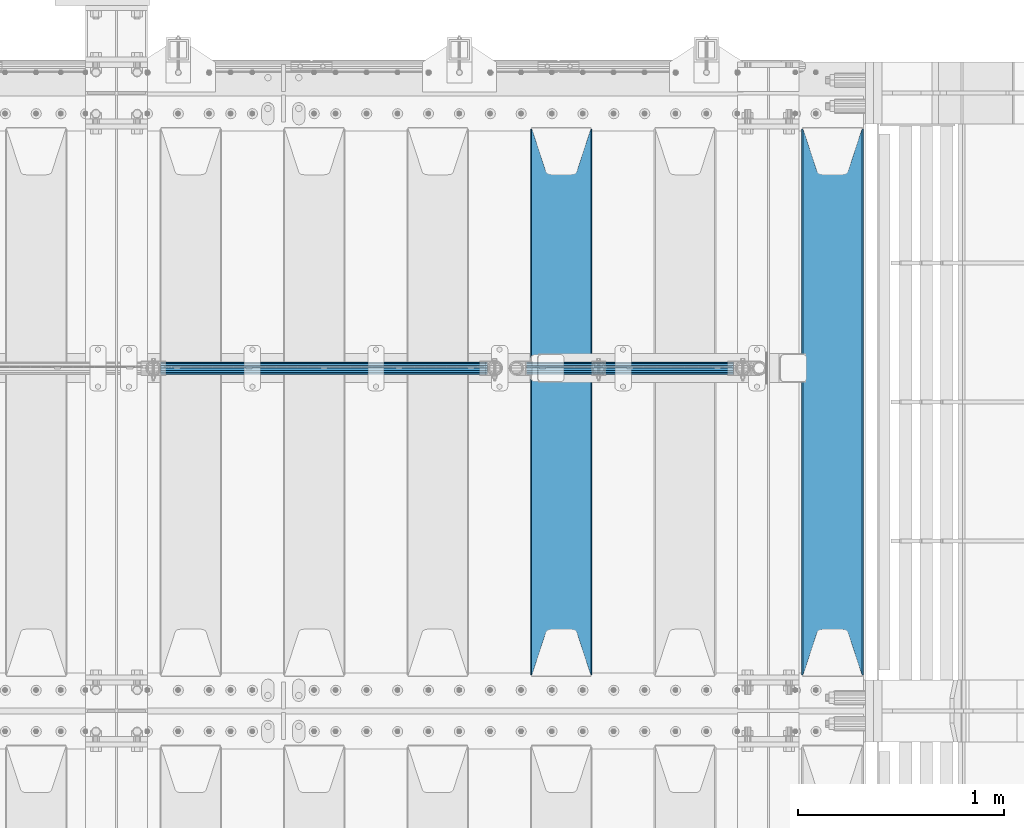
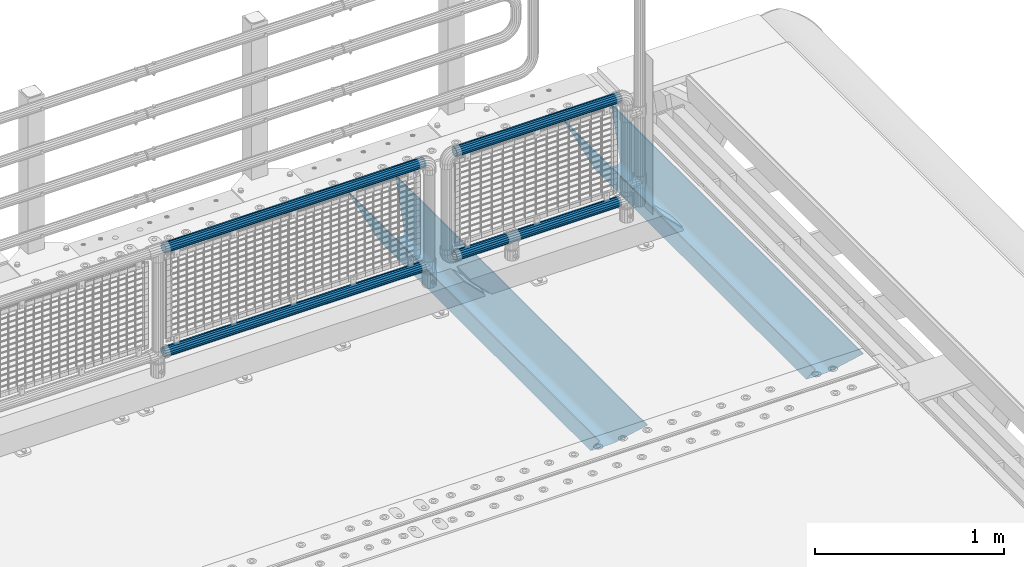
# One storey, part 101 of 193: 6 beams.
"""IFC2X3 building model written with IfcOpenShell, lengths in millimetres."""

from ifc_helpers import new_model, si_unit, frame, origin_with_axes, place, context, subcontext, project, spatial, faceted_brep, material, type_object, element, save


model = new_model("IFC2X3")

# Units and contexts
model_context = context("Model", 3, precision=1e-05, world=origin_with_axes())
body_context = subcontext(model_context, "Body", "Model", "MODEL_VIEW")
ifc_project = project(units=[si_unit("LENGTHUNIT", "METRE", prefix="MILLI"), si_unit("AREAUNIT", "SQUARE_METRE"), si_unit("VOLUMEUNIT", "CUBIC_METRE"), si_unit("MASSUNIT", "GRAM", prefix="KILO"), si_unit("TIMEUNIT", "SECOND"), si_unit("PLANEANGLEUNIT", "RADIAN"), si_unit("SOLIDANGLEUNIT", "STERADIAN"), si_unit("THERMODYNAMICTEMPERATUREUNIT", "DEGREE_CELSIUS"), si_unit("LUMINOUSINTENSITYUNIT", "LUMEN")], contexts=[model_context])

# Site, building, storey
site_placement = place(None, origin_with_axes())
site = spatial("IfcSite", under=ifc_project, at=site_placement, CompositionType="ELEMENT")
building_placement = place(site_placement, origin_with_axes())
building = spatial("IfcBuilding", under=site, at=building_placement, Name="Standard", CompositionType="ELEMENT")
storey_placement = place(building_placement, origin_with_axes())
storey = spatial("IfcBuildingStorey", under=building, at=storey_placement, Name="Undefined", CompositionType="ELEMENT", Elevation=0.0)

# Beams
ifc_material_1 = material(Name="STEEL/S355N")
beam_type_1 = type_object("IfcBeamType", PredefinedType="NOTDEFINED")
beam_1_placement = place(storey_placement, frame((-28583.0, 27175.0, -115.0), z_axis=(0.0, 0.0, 1.0), x_axis=(0.0, 1.0, 0.0)))
element("IfcBeam", 1, at=beam_1_placement, inside=storey, type_object=beam_type_1, material=ifc_material_1, context=body_context, shape_type="Brep", body=[
    faceted_brep([(0.0, 150.0, 115.0), (0.0, 143.689999999999, 115.0), (2650.00000000297, 143.689999999999, 115.0), (2650.00000000297, 150.0, 115.0), (2650.00000000297, 142.059565218398, 110.000000003094), (2650.00000000297, 148.3695652184, 110.000000003094), (2441.90079219209, -80.1103600731112, -98.0992078077845), (2437.7588105432, -77.5672621345584, -102.241189456673), (2434.06523489747, -74.4080125315522, -105.934765102404), (2430.9108609509, -70.710272125576, -109.089139048974), (2428.37322971128, -66.5649389910068, -111.626770288588), (2426.51472138055, -62.0739139532889, -113.485278619323), (2425.38102192092, -57.3475956567672, -114.618978078955), (2424.99999999988, -52.5021667386536, -115.0), (2424.99999999988, 52.5021667386536, -115.0), (2425.38102192092, 57.3475956567672, -114.618978078955), (2426.51472138055, 62.0739139532889, -113.485278619323), (2428.37322971128, 66.5649389910068, -111.626770288588), (2430.9108609509, 70.710272125576, -109.089139048974), (2434.06523489747, 74.4080125315522, -105.934765102404), (2437.7588105432, 77.5672621345584, -102.241189456673), (2441.90079219209, 80.1103600731112, -98.0992078077846), (2446.38936140512, 81.9747917625791, -93.6106385947584), (2448.2494850041, 76.2713538057251, -91.7505149957729), (2444.62967112263, 74.76777986261, -95.3703288772456), (2441.28936334127, 72.7168944282894, -98.710636658607), (2438.31067330439, 70.1691124903846, -101.689326695487), (2435.76682334748, 67.1870637758839, -104.233176652398), (2433.72034654134, 63.8440531834895, -106.279653458539), (2432.22154950042, 60.222258798236, -107.778450499454), (2431.30727574265, 56.4107117849089, -108.692724257221), (2430.99999999987, 52.5031078186876, -109.0), (2430.99999999987, -52.5031078186876, -109.0), (2431.30727574265, -56.4107117849089, -108.692724257221), (2432.22154950042, -60.222258798236, -107.778450499454), (2433.72034654134, -63.8440531834895, -106.279653458539), (2435.76682334748, -67.1870637758839, -104.233176652398), (2438.31067330439, -70.1691124903846, -101.689326695487), (2441.28936334127, -72.7168944282894, -98.7106366586071), (2444.62967112263, -74.76777986261, -95.3703288772457), (2448.2494850041, -76.2713538057251, -91.7505149957729), (2650.00000000297, -142.059565218398, 110.000000003094), (2650.00000000297, -148.3695652184, 110.000000003094), (2446.38936140512, -81.9747917625791, -93.6106385947584), (2650.00000000297, -143.689999999999, 115.0), (2650.00000000297, -150.0, 115.0), (0.0, -143.689999999999, 115.0), (0.0, -150.0, 115.0), (0.0, -148.369565218261, 110.000000002667), (203.610638597427, -81.9747917625791, -93.6106385947584), (208.099207810446, -80.1103600731112, -98.0992078077845), (212.241189459342, -77.5672621345584, -102.241189456673), (215.93476510507, -74.4080125315522, -105.934765102404), (219.089139051641, -70.710272125576, -109.089139048974), (221.626770291256, -66.5649389910068, -111.626770288588), (223.485278621989, -62.0739139532889, -113.485278619323), (224.618978081624, -57.3475956567672, -114.618978078955), (225.000000002663, -52.5021667386536, -115.0), (225.000000002663, 52.5021667386536, -115.0), (224.618978081624, 57.3475956567672, -114.618978078955), (223.485278621989, 62.0739139532889, -113.485278619323), (221.626770291256, 66.5649389910068, -111.626770288588), (219.089139051641, 70.710272125576, -109.089139048974), (215.93476510507, 74.4080125315522, -105.934765102404), (212.241189459342, 77.5672621345584, -102.241189456673), (208.099207810446, 80.1103600731112, -98.0992078077846), (203.610638597427, 81.9747917625791, -93.6106385947584), (0.0, 148.369565218261, 110.000000002667), (0.0, 142.05956521826, 110.000000002667), (201.750514998439, 76.2713538057251, -91.7505149957729), (205.370328879915, 74.76777986261, -95.3703288772456), (208.710636661275, 72.7168944282894, -98.710636658607), (211.689326698157, 70.1691124903846, -101.689326695487), (214.233176655063, 67.1870637758839, -104.233176652398), (216.279653461206, 63.8440531834895, -106.279653458539), (217.778450502123, 60.222258798236, -107.778450499454), (218.69272425989, 56.4107117849089, -108.692724257221), (219.00000000267, 52.5031078186876, -109.0), (219.00000000267, -52.5031078186876, -109.0), (218.69272425989, -56.4107117849089, -108.692724257221), (217.778450502123, -60.222258798236, -107.778450499454), (216.279653461206, -63.8440531834895, -106.279653458539), (214.233176655063, -67.1870637758839, -104.233176652398), (211.689326698157, -70.1691124903846, -101.689326695487), (208.710636661275, -72.7168944282894, -98.7106366586071), (205.370328879915, -74.76777986261, -95.3703288772457), (201.750514998439, -76.2713538057251, -91.7505149957729), (0.0, -142.05956521826, 110.000000002667)], [[[0, 1, 2, 3]], [[3, 2, 4, 5]], [[6, 7, 8, 9, 10, 11, 12, 13, 14, 15, 16, 17, 18, 19, 20, 21, 22, 5, 4, 23, 24, 25, 26, 27, 28, 29, 30, 31, 32, 33, 34, 35, 36, 37, 38, 39, 40, 41, 42, 43]], [[44, 45, 42, 41]], [[46, 47, 45, 44]], [[43, 42, 45, 47, 48, 49]], [[6, 43, 49, 50]], [[7, 6, 50, 51]], [[8, 7, 51, 52]], [[9, 8, 52, 53]], [[10, 9, 53, 54]], [[11, 10, 54, 55]], [[12, 11, 55, 56]], [[13, 12, 56, 57]], [[14, 13, 57, 58]], [[15, 14, 58, 59]], [[16, 15, 59, 60]], [[17, 16, 60, 61]], [[18, 17, 61, 62]], [[19, 18, 62, 63]], [[20, 19, 63, 64]], [[21, 20, 64, 65]], [[22, 21, 65, 66]], [[0, 3, 5, 22, 66, 67]], [[1, 0, 67, 68]], [[23, 4, 2, 1, 68, 69]], [[24, 23, 69, 70]], [[25, 24, 70, 71]], [[26, 25, 71, 72]], [[27, 26, 72, 73]], [[28, 27, 73, 74]], [[29, 28, 74, 75]], [[30, 29, 75, 76]], [[31, 30, 76, 77]], [[32, 31, 77, 78]], [[33, 32, 78, 79]], [[34, 33, 79, 80]], [[35, 34, 80, 81]], [[36, 35, 81, 82]], [[37, 36, 82, 83]], [[38, 37, 83, 84]], [[39, 38, 84, 85]], [[40, 39, 85, 86]], [[46, 44, 41, 40, 86, 87]], [[47, 46, 87, 48]], [[86, 85, 84, 83, 82, 81, 80, 79, 78, 77, 76, 75, 74, 73, 72, 71, 70, 69, 68, 67, 66, 65, 64, 63, 62, 61, 60, 59, 58, 57, 56, 55, 54, 53, 52, 51, 50, 49, 48, 87]]]),
])
beam_2_placement = place(storey_placement, frame((-29900.0, 27175.0, -115.0), z_axis=(0.0, 0.0, 1.0), x_axis=(0.0, 1.0, 0.0)))
element("IfcBeam", 2, at=beam_2_placement, inside=storey, type_object=beam_type_1, material=ifc_material_1, context=body_context, shape_type="Brep", body=[
    faceted_brep([(0.0, 150.0, 115.0), (0.0, 143.689999999999, 115.0), (2650.00000000297, 143.689999999999, 115.0), (2650.00000000297, 150.0, 115.0), (2650.00000000297, 142.059565218398, 110.000000003094), (2650.00000000297, 148.3695652184, 110.000000003094), (2441.90079219209, -80.1103600731112, -98.0992078077845), (2437.7588105432, -77.5672621345584, -102.241189456673), (2434.06523489747, -74.4080125315522, -105.934765102404), (2430.9108609509, -70.710272125576, -109.089139048974), (2428.37322971128, -66.5649389910068, -111.626770288588), (2426.51472138055, -62.0739139532889, -113.485278619323), (2425.38102192092, -57.3475956567672, -114.618978078955), (2424.99999999988, -52.5021667386536, -115.0), (2424.99999999988, 52.5021667386536, -115.0), (2425.38102192092, 57.3475956567672, -114.618978078955), (2426.51472138055, 62.0739139532889, -113.485278619323), (2428.37322971128, 66.5649389910068, -111.626770288588), (2430.9108609509, 70.710272125576, -109.089139048974), (2434.06523489747, 74.4080125315522, -105.934765102404), (2437.7588105432, 77.5672621345584, -102.241189456673), (2441.90079219209, 80.1103600731112, -98.0992078077846), (2446.38936140512, 81.9747917625791, -93.6106385947584), (2448.2494850041, 76.2713538057251, -91.7505149957729), (2444.62967112263, 74.76777986261, -95.3703288772456), (2441.28936334127, 72.7168944282894, -98.710636658607), (2438.31067330439, 70.1691124903846, -101.689326695487), (2435.76682334748, 67.1870637758839, -104.233176652398), (2433.72034654134, 63.8440531834895, -106.279653458539), (2432.22154950042, 60.222258798236, -107.778450499454), (2431.30727574265, 56.4107117849089, -108.692724257221), (2430.99999999987, 52.5031078186876, -109.0), (2430.99999999987, -52.5031078186876, -109.0), (2431.30727574265, -56.4107117849089, -108.692724257221), (2432.22154950042, -60.222258798236, -107.778450499454), (2433.72034654134, -63.8440531834895, -106.279653458539), (2435.76682334748, -67.1870637758839, -104.233176652398), (2438.31067330439, -70.1691124903846, -101.689326695487), (2441.28936334127, -72.7168944282894, -98.7106366586071), (2444.62967112263, -74.76777986261, -95.3703288772457), (2448.2494850041, -76.2713538057251, -91.7505149957729), (2650.00000000297, -142.059565218398, 110.000000003094), (2650.00000000297, -148.3695652184, 110.000000003094), (2446.38936140512, -81.9747917625791, -93.6106385947584), (2650.00000000297, -143.689999999999, 115.0), (2650.00000000297, -150.0, 115.0), (0.0, -143.689999999999, 115.0), (0.0, -150.0, 115.0), (0.0, -148.369565218261, 110.000000002667), (203.610638597427, -81.9747917625791, -93.6106385947584), (208.099207810446, -80.1103600731112, -98.0992078077845), (212.241189459342, -77.5672621345584, -102.241189456673), (215.93476510507, -74.4080125315522, -105.934765102404), (219.089139051641, -70.710272125576, -109.089139048974), (221.626770291256, -66.5649389910068, -111.626770288588), (223.485278621989, -62.0739139532889, -113.485278619323), (224.618978081624, -57.3475956567672, -114.618978078955), (225.000000002663, -52.5021667386536, -115.0), (225.000000002663, 52.5021667386536, -115.0), (224.618978081624, 57.3475956567672, -114.618978078955), (223.485278621989, 62.0739139532889, -113.485278619323), (221.626770291256, 66.5649389910068, -111.626770288588), (219.089139051641, 70.710272125576, -109.089139048974), (215.93476510507, 74.4080125315522, -105.934765102404), (212.241189459342, 77.5672621345584, -102.241189456673), (208.099207810446, 80.1103600731112, -98.0992078077846), (203.610638597427, 81.9747917625791, -93.6106385947584), (0.0, 148.369565218261, 110.000000002667), (0.0, 142.05956521826, 110.000000002667), (201.750514998439, 76.2713538057251, -91.7505149957729), (205.370328879915, 74.76777986261, -95.3703288772456), (208.710636661275, 72.7168944282894, -98.710636658607), (211.689326698157, 70.1691124903846, -101.689326695487), (214.233176655063, 67.1870637758839, -104.233176652398), (216.279653461206, 63.8440531834895, -106.279653458539), (217.778450502123, 60.222258798236, -107.778450499454), (218.69272425989, 56.4107117849089, -108.692724257221), (219.00000000267, 52.5031078186876, -109.0), (219.00000000267, -52.5031078186876, -109.0), (218.69272425989, -56.4107117849089, -108.692724257221), (217.778450502123, -60.222258798236, -107.778450499454), (216.279653461206, -63.8440531834895, -106.279653458539), (214.233176655063, -67.1870637758839, -104.233176652398), (211.689326698157, -70.1691124903846, -101.689326695487), (208.710636661275, -72.7168944282894, -98.7106366586071), (205.370328879915, -74.76777986261, -95.3703288772457), (201.750514998439, -76.2713538057251, -91.7505149957729), (0.0, -142.05956521826, 110.000000002667)], [[[0, 1, 2, 3]], [[3, 2, 4, 5]], [[6, 7, 8, 9, 10, 11, 12, 13, 14, 15, 16, 17, 18, 19, 20, 21, 22, 5, 4, 23, 24, 25, 26, 27, 28, 29, 30, 31, 32, 33, 34, 35, 36, 37, 38, 39, 40, 41, 42, 43]], [[44, 45, 42, 41]], [[46, 47, 45, 44]], [[43, 42, 45, 47, 48, 49]], [[6, 43, 49, 50]], [[7, 6, 50, 51]], [[8, 7, 51, 52]], [[9, 8, 52, 53]], [[10, 9, 53, 54]], [[11, 10, 54, 55]], [[12, 11, 55, 56]], [[13, 12, 56, 57]], [[14, 13, 57, 58]], [[15, 14, 58, 59]], [[16, 15, 59, 60]], [[17, 16, 60, 61]], [[18, 17, 61, 62]], [[19, 18, 62, 63]], [[20, 19, 63, 64]], [[21, 20, 64, 65]], [[22, 21, 65, 66]], [[0, 3, 5, 22, 66, 67]], [[1, 0, 67, 68]], [[23, 4, 2, 1, 68, 69]], [[24, 23, 69, 70]], [[25, 24, 70, 71]], [[26, 25, 71, 72]], [[27, 26, 72, 73]], [[28, 27, 73, 74]], [[29, 28, 74, 75]], [[30, 29, 75, 76]], [[31, 30, 76, 77]], [[32, 31, 77, 78]], [[33, 32, 78, 79]], [[34, 33, 79, 80]], [[35, 34, 80, 81]], [[36, 35, 81, 82]], [[37, 36, 82, 83]], [[38, 37, 83, 84]], [[39, 38, 84, 85]], [[40, 39, 85, 86]], [[46, 44, 41, 40, 86, 87]], [[47, 46, 87, 48]], [[86, 85, 84, 83, 82, 81, 80, 79, 78, 77, 76, 75, 74, 73, 72, 71, 70, 69, 68, 67, 66, 65, 64, 63, 62, 61, 60, 59, 58, 57, 56, 55, 54, 53, 52, 51, 50, 49, 48, 87]]]),
])
ifc_material_2 = material()
beam_type_2 = type_object("IfcBeamType", PredefinedType="NOTDEFINED")
beam_3_placement = place(storey_placement, frame((-31846.15, 28664.5, 969.850000000001), z_axis=(0.0, 0.0, 1.0), x_axis=(1.0, 0.0, 0.0)))
element("IfcBeam", 3, at=beam_3_placement, inside=storey, type_object=beam_type_2, material=ifc_material_2, context=body_context, shape_type="Brep", body=[
    faceted_brep([(0.0, -25.3499999999985, 0.0), (0.0, -23.4203461491597, 9.70102501045403), (1588.0, -23.4203461491597, 9.70102501045506), (1588.0, -25.3499999999985, 0.0), (0.0, -17.9251569030785, 17.9251569030785), (1588.0, -17.9251569030785, 17.925156903079), (0.0, -9.70102501045403, 23.4203461491597), (1588.0, -9.70102501045403, 23.4203461491611), (0.0, 0.0, 25.3499999999985), (1588.0, 0.0, 25.35), (0.0, 9.70102501045403, 23.4203461491597), (1588.0, 9.70102501045403, 23.4203461491611), (0.0, 17.9251569030785, 17.9251569030785), (1588.0, 17.9251569030785, 17.925156903079), (0.0, 23.4203461491597, 9.70102501045403), (1588.0, 23.4203461491597, 9.70102501045506), (0.0, 25.3499999999985, 0.0), (1588.0, 25.3499999999985, 0.0), (0.0, 23.4203461491597, -9.70102501045403), (1588.0, 23.4203461491597, -9.70102501045506), (0.0, 17.9251569030785, -17.9251569030785), (1588.0, 17.9251569030785, -17.925156903079), (0.0, 9.70102501045403, -23.4203461491597), (1588.0, 9.70102501045403, -23.4203461491611), (0.0, 0.0, -25.3499999999985), (1588.0, 0.0, -25.35), (0.0, -9.70102501045403, -23.4203461491597), (1588.0, -9.70102501045403, -23.4203461491611), (0.0, -17.9251569030785, -17.9251569030785), (1588.0, -17.9251569030785, -17.925156903079), (0.0, -23.4203461491597, -9.70102501045403), (1588.0, -23.4203461491597, -9.70102501045506), (0.0, -30.1500000000015, 0.0), (0.0, -27.8549679052157, -11.5379054858058), (1588.0, -27.8549679052157, -11.5379054858075), (1588.0, -30.1500000000015, 0.0), (0.0, -21.3192694527752, -21.3192694527752), (1588.0, -21.3192694527752, -21.3192694527744), (0.0, -11.5379054858058, -27.8549679052157), (1588.0, -11.5379054858058, -27.8549679052153), (0.0, 0.0, -30.1500000000015), (1588.0, 0.0, -30.15), (0.0, 11.5379054858058, -27.8549679052157), (1588.0, 11.5379054858058, -27.8549679052153), (0.0, 21.3192694527752, -21.3192694527752), (1588.0, 21.3192694527752, -21.3192694527744), (0.0, 27.8549679052157, -11.5379054858058), (1588.0, 27.8549679052157, -11.5379054858074), (0.0, 30.1500000000015, 0.0), (1588.0, 30.1500000000015, 0.0), (0.0, 27.8549679052157, 11.5379054858058), (1588.0, 27.8549679052157, 11.5379054858074), (0.0, 21.3192694527752, 21.3192694527752), (1588.0, 21.3192694527752, 21.3192694527744), (0.0, 11.5379054858058, 27.8549679052157), (1588.0, 11.5379054858058, 27.8549679052153), (0.0, 0.0, 30.1500000000015), (1588.0, 0.0, 30.15), (0.0, -11.5379054858058, 27.8549679052157), (1588.0, -11.5379054858058, 27.8549679052153), (0.0, -21.3192694527752, 21.3192694527752), (1588.0, -21.3192694527752, 21.3192694527744), (0.0, -27.8549679052157, 11.5379054858058), (1588.0, -27.8549679052157, 11.5379054858074)], [[[0, 1, 2, 3]], [[1, 4, 5, 2]], [[4, 6, 7, 5]], [[6, 8, 9, 7]], [[8, 10, 11, 9]], [[10, 12, 13, 11]], [[12, 14, 15, 13]], [[14, 16, 17, 15]], [[16, 18, 19, 17]], [[18, 20, 21, 19]], [[20, 22, 23, 21]], [[22, 24, 25, 23]], [[24, 26, 27, 25]], [[26, 28, 29, 27]], [[28, 30, 31, 29]], [[30, 0, 3, 31]], [[32, 33, 34, 35]], [[33, 36, 37, 34]], [[36, 38, 39, 37]], [[38, 40, 41, 39]], [[40, 42, 43, 41]], [[42, 44, 45, 43]], [[44, 46, 47, 45]], [[46, 48, 49, 47]], [[48, 50, 51, 49]], [[50, 52, 53, 51]], [[52, 54, 55, 53]], [[54, 56, 57, 55]], [[56, 58, 59, 57]], [[58, 60, 61, 59]], [[60, 62, 63, 61]], [[62, 32, 35, 63]], [[37, 39, 41, 43, 45, 47, 49, 51, 53, 55, 57, 59, 61, 63, 35, 34], [5, 7, 9, 11, 13, 15, 17, 19, 21, 23, 25, 27, 29, 31, 3, 2]], [[62, 60, 58, 56, 54, 52, 50, 48, 46, 44, 42, 40, 38, 36, 33, 32], [30, 28, 26, 24, 22, 20, 18, 16, 14, 12, 10, 8, 6, 4, 1, 0]]]),
])
beam_4_placement = place(storey_placement, frame((-31846.15, 28664.5, 298.170000000003), z_axis=(0.0, 0.0, 1.0), x_axis=(1.0, 0.0, 0.0)))
element("IfcBeam", 4, at=beam_4_placement, inside=storey, type_object=beam_type_2, material=ifc_material_2, context=body_context, shape_type="Brep", body=[
    faceted_brep([(0.0, -25.3499999999985, 0.0), (0.0, -23.4203461491597, 9.70102501045403), (1588.0, -23.4203461491597, 9.70102501045506), (1588.0, -25.3499999999985, 0.0), (0.0, -17.9251569030785, 17.9251569030785), (1588.0, -17.9251569030785, 17.925156903079), (0.0, -9.70102501045403, 23.4203461491597), (1588.0, -9.70102501045403, 23.4203461491611), (0.0, 0.0, 25.3499999999985), (1588.0, 0.0, 25.35), (0.0, 9.70102501045403, 23.4203461491597), (1588.0, 9.70102501045403, 23.4203461491611), (0.0, 17.9251569030785, 17.9251569030785), (1588.0, 17.9251569030785, 17.925156903079), (0.0, 23.4203461491597, 9.70102501045403), (1588.0, 23.4203461491597, 9.70102501045506), (0.0, 25.3499999999985, 0.0), (1588.0, 25.3499999999985, 0.0), (0.0, 23.4203461491597, -9.70102501045403), (1588.0, 23.4203461491597, -9.70102501045506), (0.0, 17.9251569030785, -17.9251569030785), (1588.0, 17.9251569030785, -17.925156903079), (0.0, 9.70102501045403, -23.4203461491597), (1588.0, 9.70102501045403, -23.4203461491611), (0.0, 0.0, -25.3499999999985), (1588.0, 0.0, -25.35), (0.0, -9.70102501045403, -23.4203461491597), (1588.0, -9.70102501045403, -23.4203461491611), (0.0, -17.9251569030785, -17.9251569030785), (1588.0, -17.9251569030785, -17.925156903079), (0.0, -23.4203461491597, -9.70102501045403), (1588.0, -23.4203461491597, -9.70102501045506), (0.0, -30.1500000000015, 0.0), (0.0, -27.8549679052157, -11.5379054858058), (1588.0, -27.8549679052157, -11.5379054858075), (1588.0, -30.1500000000015, 0.0), (0.0, -21.3192694527752, -21.3192694527752), (1588.0, -21.3192694527752, -21.3192694527744), (0.0, -11.5379054858058, -27.8549679052157), (1588.0, -11.5379054858058, -27.8549679052153), (0.0, 0.0, -30.1500000000015), (1588.0, 0.0, -30.15), (0.0, 11.5379054858058, -27.8549679052157), (1588.0, 11.5379054858058, -27.8549679052153), (0.0, 21.3192694527752, -21.3192694527752), (1588.0, 21.3192694527752, -21.3192694527744), (0.0, 27.8549679052157, -11.5379054858058), (1588.0, 27.8549679052157, -11.5379054858074), (0.0, 30.1500000000015, 0.0), (1588.0, 30.1500000000015, 0.0), (0.0, 27.8549679052157, 11.5379054858058), (1588.0, 27.8549679052157, 11.5379054858074), (0.0, 21.3192694527752, 21.3192694527752), (1588.0, 21.3192694527752, 21.3192694527744), (0.0, 11.5379054858058, 27.8549679052157), (1588.0, 11.5379054858058, 27.8549679052153), (0.0, 0.0, 30.1500000000015), (1588.0, 0.0, 30.15), (0.0, -11.5379054858058, 27.8549679052157), (1588.0, -11.5379054858058, 27.8549679052153), (0.0, -21.3192694527752, 21.3192694527752), (1588.0, -21.3192694527752, 21.3192694527744), (0.0, -27.8549679052157, 11.5379054858058), (1588.0, -27.8549679052157, 11.5379054858074)], [[[0, 1, 2, 3]], [[1, 4, 5, 2]], [[4, 6, 7, 5]], [[6, 8, 9, 7]], [[8, 10, 11, 9]], [[10, 12, 13, 11]], [[12, 14, 15, 13]], [[14, 16, 17, 15]], [[16, 18, 19, 17]], [[18, 20, 21, 19]], [[20, 22, 23, 21]], [[22, 24, 25, 23]], [[24, 26, 27, 25]], [[26, 28, 29, 27]], [[28, 30, 31, 29]], [[30, 0, 3, 31]], [[32, 33, 34, 35]], [[33, 36, 37, 34]], [[36, 38, 39, 37]], [[38, 40, 41, 39]], [[40, 42, 43, 41]], [[42, 44, 45, 43]], [[44, 46, 47, 45]], [[46, 48, 49, 47]], [[48, 50, 51, 49]], [[50, 52, 53, 51]], [[52, 54, 55, 53]], [[54, 56, 57, 55]], [[56, 58, 59, 57]], [[58, 60, 61, 59]], [[60, 62, 63, 61]], [[62, 32, 35, 63]], [[37, 39, 41, 43, 45, 47, 49, 51, 53, 55, 57, 59, 61, 63, 35, 34], [5, 7, 9, 11, 13, 15, 17, 19, 21, 23, 25, 27, 29, 31, 3, 2]], [[62, 60, 58, 56, 54, 52, 50, 48, 46, 44, 42, 40, 38, 36, 33, 32], [30, 28, 26, 24, 22, 20, 18, 16, 14, 12, 10, 8, 6, 4, 1, 0]]]),
])
beam_5_placement = place(storey_placement, frame((-30068.4, 28664.5, 298.170000000001), z_axis=(0.0, 0.0, 1.0), x_axis=(1.0, 0.0, 0.0)))
element("IfcBeam", 5, at=beam_5_placement, inside=storey, type_object=beam_type_2, material=ifc_material_2, context=body_context, shape_type="Brep", body=[
    faceted_brep([(0.0, -25.3499999999985, 0.0), (0.0, -23.4203461491597, 9.70102501045403), (1005.0, -23.4203461491597, 9.70102501045506), (1005.0, -25.3499999999985, 0.0), (0.0, -17.9251569030785, 17.9251569030785), (1005.0, -17.9251569030785, 17.925156903079), (0.0, -9.70102501045403, 23.4203461491597), (1005.0, -9.70102501045403, 23.4203461491611), (0.0, 0.0, 25.3499999999985), (1005.0, 0.0, 25.35), (0.0, 9.70102501045403, 23.4203461491597), (1005.0, 9.70102501045403, 23.4203461491611), (0.0, 17.9251569030785, 17.9251569030785), (1005.0, 17.9251569030785, 17.925156903079), (0.0, 23.4203461491597, 9.70102501045403), (1005.0, 23.4203461491597, 9.701025010455), (0.0, 25.3499999999985, 0.0), (1005.0, 25.3499999999985, 0.0), (0.0, 23.4203461491597, -9.70102501045403), (1005.0, 23.4203461491597, -9.70102501045506), (0.0, 17.9251569030785, -17.9251569030785), (1005.0, 17.9251569030785, -17.925156903079), (0.0, 9.70102501045403, -23.4203461491597), (1005.0, 9.70102501045403, -23.4203461491611), (0.0, 0.0, -25.3499999999985), (1005.0, 0.0, -25.35), (0.0, -9.70102501045403, -23.4203461491597), (1005.0, -9.70102501045403, -23.4203461491611), (0.0, -17.9251569030785, -17.9251569030785), (1005.0, -17.9251569030785, -17.925156903079), (0.0, -23.4203461491597, -9.70102501045403), (1005.0, -23.4203461491597, -9.701025010455), (0.0, -30.1500000000015, 0.0), (0.0, -27.8549679052157, -11.5379054858058), (1005.0, -27.8549679052157, -11.5379054858075), (1005.0, -30.1500000000015, 0.0), (0.0, -21.3192694527752, -21.3192694527752), (1005.0, -21.3192694527752, -21.3192694527744), (0.0, -11.5379054858058, -27.8549679052157), (1005.0, -11.5379054858058, -27.8549679052153), (0.0, 0.0, -30.1500000000015), (1005.0, 0.0, -30.15), (0.0, 11.5379054858058, -27.8549679052157), (1005.0, 11.5379054858058, -27.8549679052153), (0.0, 21.3192694527752, -21.3192694527752), (1005.0, 21.3192694527752, -21.3192694527744), (0.0, 27.8549679052157, -11.5379054858058), (1005.0, 27.8549679052157, -11.5379054858075), (0.0, 30.1500000000015, 0.0), (1005.0, 30.1500000000015, 0.0), (0.0, 27.8549679052157, 11.5379054858058), (1005.0, 27.8549679052157, 11.5379054858075), (0.0, 21.3192694527752, 21.3192694527752), (1005.0, 21.3192694527752, 21.3192694527744), (0.0, 11.5379054858058, 27.8549679052157), (1005.0, 11.5379054858058, 27.8549679052153), (0.0, 0.0, 30.1500000000015), (1005.0, 0.0, 30.15), (0.0, -11.5379054858058, 27.8549679052157), (1005.0, -11.5379054858058, 27.8549679052153), (0.0, -21.3192694527752, 21.3192694527752), (1005.0, -21.3192694527752, 21.3192694527744), (0.0, -27.8549679052157, 11.5379054858058), (1005.0, -27.8549679052157, 11.5379054858075)], [[[0, 1, 2, 3]], [[1, 4, 5, 2]], [[4, 6, 7, 5]], [[6, 8, 9, 7]], [[8, 10, 11, 9]], [[10, 12, 13, 11]], [[12, 14, 15, 13]], [[14, 16, 17, 15]], [[16, 18, 19, 17]], [[18, 20, 21, 19]], [[20, 22, 23, 21]], [[22, 24, 25, 23]], [[24, 26, 27, 25]], [[26, 28, 29, 27]], [[28, 30, 31, 29]], [[30, 0, 3, 31]], [[32, 33, 34, 35]], [[33, 36, 37, 34]], [[36, 38, 39, 37]], [[38, 40, 41, 39]], [[40, 42, 43, 41]], [[42, 44, 45, 43]], [[44, 46, 47, 45]], [[46, 48, 49, 47]], [[48, 50, 51, 49]], [[50, 52, 53, 51]], [[52, 54, 55, 53]], [[54, 56, 57, 55]], [[56, 58, 59, 57]], [[58, 60, 61, 59]], [[60, 62, 63, 61]], [[62, 32, 35, 63]], [[37, 39, 41, 43, 45, 47, 49, 51, 53, 55, 57, 59, 61, 63, 35, 34], [5, 7, 9, 11, 13, 15, 17, 19, 21, 23, 25, 27, 29, 31, 3, 2]], [[62, 60, 58, 56, 54, 52, 50, 48, 46, 44, 42, 40, 38, 36, 33, 32], [30, 28, 26, 24, 22, 20, 18, 16, 14, 12, 10, 8, 6, 4, 1, 0]]]),
])
beam_6_placement = place(storey_placement, frame((-30069.0, 28664.5, 969.85), z_axis=(0.0, 0.0, 1.0), x_axis=(1.0, 0.0, 0.0)))
element("IfcBeam", 6, at=beam_6_placement, inside=storey, type_object=beam_type_2, material=ifc_material_2, context=body_context, shape_type="Brep", body=[
    faceted_brep([(0.0, -25.3499999999985, 0.0), (0.0, -23.4203461491597, 9.70102501045403), (1005.0, -23.4203461491597, 9.70102501045506), (1005.0, -25.3499999999985, 0.0), (0.0, -17.9251569030785, 17.9251569030785), (1005.0, -17.9251569030785, 17.925156903079), (0.0, -9.70102501045403, 23.4203461491597), (1005.0, -9.70102501045403, 23.4203461491611), (0.0, 0.0, 25.3499999999985), (1005.0, 0.0, 25.35), (0.0, 9.70102501045403, 23.4203461491597), (1005.0, 9.70102501045403, 23.4203461491611), (0.0, 17.9251569030785, 17.9251569030785), (1005.0, 17.9251569030785, 17.925156903079), (0.0, 23.4203461491597, 9.70102501045403), (1005.0, 23.4203461491597, 9.701025010455), (0.0, 25.3499999999985, 0.0), (1005.0, 25.3499999999985, 0.0), (0.0, 23.4203461491597, -9.70102501045403), (1005.0, 23.4203461491597, -9.70102501045506), (0.0, 17.9251569030785, -17.9251569030785), (1005.0, 17.9251569030785, -17.925156903079), (0.0, 9.70102501045403, -23.4203461491597), (1005.0, 9.70102501045403, -23.4203461491611), (0.0, 0.0, -25.3499999999985), (1005.0, 0.0, -25.35), (0.0, -9.70102501045403, -23.4203461491597), (1005.0, -9.70102501045403, -23.4203461491611), (0.0, -17.9251569030785, -17.9251569030785), (1005.0, -17.9251569030785, -17.925156903079), (0.0, -23.4203461491597, -9.70102501045403), (1005.0, -23.4203461491597, -9.701025010455), (0.0, -30.1500000000015, 0.0), (0.0, -27.8549679052157, -11.5379054858058), (1005.0, -27.8549679052157, -11.5379054858075), (1005.0, -30.1500000000015, 0.0), (0.0, -21.3192694527752, -21.3192694527752), (1005.0, -21.3192694527752, -21.3192694527744), (0.0, -11.5379054858058, -27.8549679052157), (1005.0, -11.5379054858058, -27.8549679052153), (0.0, 0.0, -30.1500000000015), (1005.0, 0.0, -30.15), (0.0, 11.5379054858058, -27.8549679052157), (1005.0, 11.5379054858058, -27.8549679052153), (0.0, 21.3192694527752, -21.3192694527752), (1005.0, 21.3192694527752, -21.3192694527744), (0.0, 27.8549679052157, -11.5379054858058), (1005.0, 27.8549679052157, -11.5379054858075), (0.0, 30.1500000000015, 0.0), (1005.0, 30.1500000000015, 0.0), (0.0, 27.8549679052157, 11.5379054858058), (1005.0, 27.8549679052157, 11.5379054858075), (0.0, 21.3192694527752, 21.3192694527752), (1005.0, 21.3192694527752, 21.3192694527744), (0.0, 11.5379054858058, 27.8549679052157), (1005.0, 11.5379054858058, 27.8549679052153), (0.0, 0.0, 30.1500000000015), (1005.0, 0.0, 30.15), (0.0, -11.5379054858058, 27.8549679052157), (1005.0, -11.5379054858058, 27.8549679052153), (0.0, -21.3192694527752, 21.3192694527752), (1005.0, -21.3192694527752, 21.3192694527744), (0.0, -27.8549679052157, 11.5379054858058), (1005.0, -27.8549679052157, 11.5379054858075)], [[[0, 1, 2, 3]], [[1, 4, 5, 2]], [[4, 6, 7, 5]], [[6, 8, 9, 7]], [[8, 10, 11, 9]], [[10, 12, 13, 11]], [[12, 14, 15, 13]], [[14, 16, 17, 15]], [[16, 18, 19, 17]], [[18, 20, 21, 19]], [[20, 22, 23, 21]], [[22, 24, 25, 23]], [[24, 26, 27, 25]], [[26, 28, 29, 27]], [[28, 30, 31, 29]], [[30, 0, 3, 31]], [[32, 33, 34, 35]], [[33, 36, 37, 34]], [[36, 38, 39, 37]], [[38, 40, 41, 39]], [[40, 42, 43, 41]], [[42, 44, 45, 43]], [[44, 46, 47, 45]], [[46, 48, 49, 47]], [[48, 50, 51, 49]], [[50, 52, 53, 51]], [[52, 54, 55, 53]], [[54, 56, 57, 55]], [[56, 58, 59, 57]], [[58, 60, 61, 59]], [[60, 62, 63, 61]], [[62, 32, 35, 63]], [[37, 39, 41, 43, 45, 47, 49, 51, 53, 55, 57, 59, 61, 63, 35, 34], [5, 7, 9, 11, 13, 15, 17, 19, 21, 23, 25, 27, 29, 31, 3, 2]], [[62, 60, 58, 56, 54, 52, 50, 48, 46, 44, 42, 40, 38, 36, 33, 32], [30, 28, 26, 24, 22, 20, 18, 16, 14, 12, 10, 8, 6, 4, 1, 0]]]),
])

save(model, "model.ifc")
